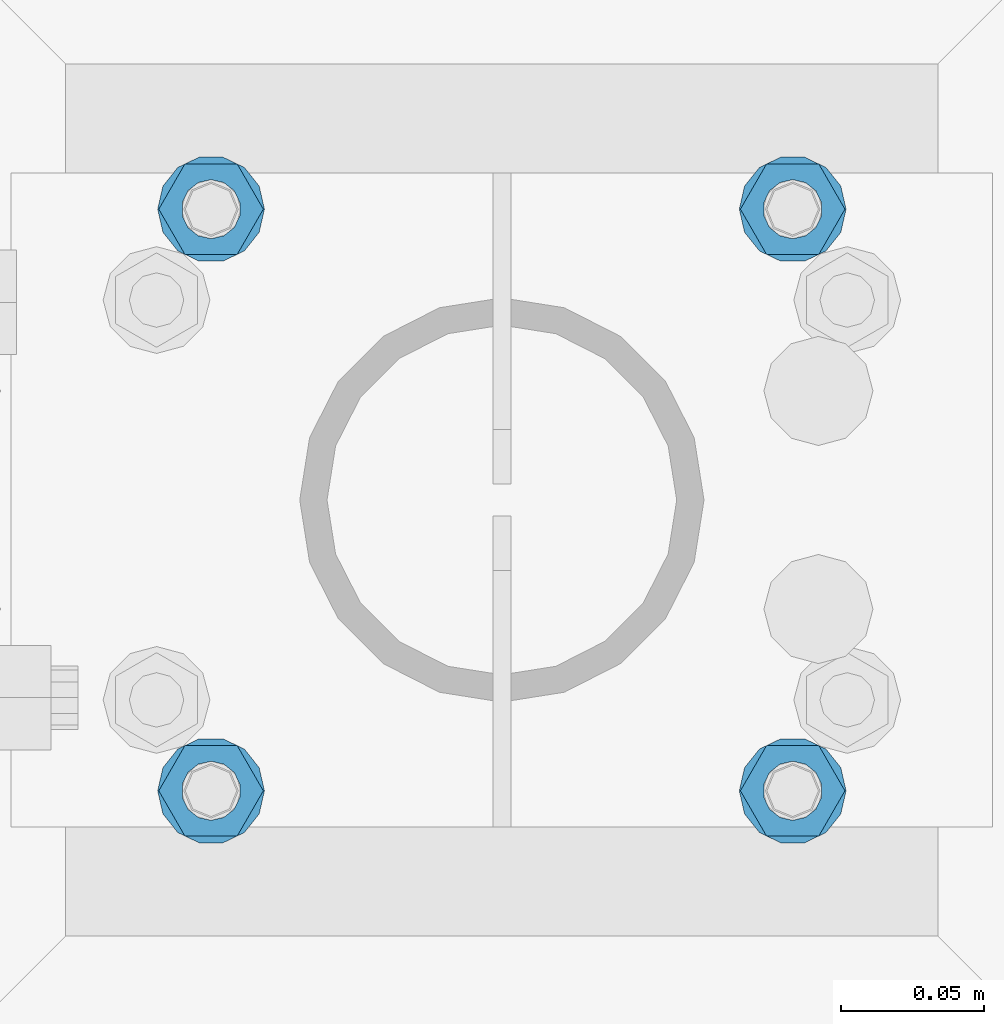
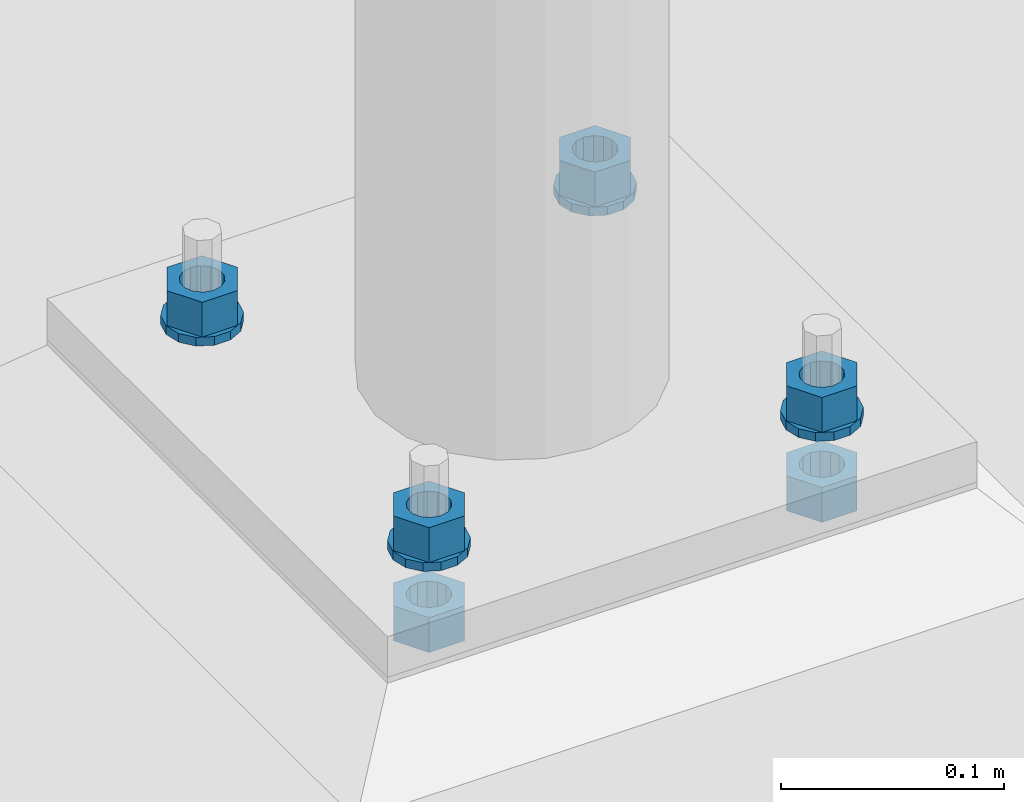
# One storey, part 545 of 975: 10 beams.
"""IFC2X3 building model written with IfcOpenShell, lengths in millimetres."""

from ifc_helpers import new_model, si_unit, frame, origin_with_axes, place, context, subcontext, project, spatial, faceted_brep, material, type_object, element, save


model = new_model("IFC2X3")

# Units and contexts
model_context = context("Model", 3, precision=1e-05, world=origin_with_axes())
body_context = subcontext(model_context, "Body", "Model", "MODEL_VIEW")
ifc_project = project(units=[si_unit("LENGTHUNIT", "METRE", prefix="MILLI"), si_unit("AREAUNIT", "SQUARE_METRE"), si_unit("VOLUMEUNIT", "CUBIC_METRE"), si_unit("MASSUNIT", "GRAM", prefix="KILO"), si_unit("TIMEUNIT", "SECOND"), si_unit("PLANEANGLEUNIT", "RADIAN"), si_unit("SOLIDANGLEUNIT", "STERADIAN"), si_unit("THERMODYNAMICTEMPERATUREUNIT", "DEGREE_CELSIUS"), si_unit("LUMINOUSINTENSITYUNIT", "LUMEN")], contexts=[model_context])

# Site, building, storey
site_placement = place(None, origin_with_axes())
site = spatial("IfcSite", under=ifc_project, at=site_placement, CompositionType="ELEMENT")
building_placement = place(site_placement, origin_with_axes())
building = spatial("IfcBuilding", under=site, at=building_placement, Name="Undefined", CompositionType="ELEMENT")
storey_placement = place(building_placement, origin_with_axes())
storey = spatial("IfcBuildingStorey", under=building, at=storey_placement, Name="Undefined", CompositionType="ELEMENT", Elevation=0.0)

# Beams
ifc_material = material(Name="STEEL/A36")
beam_type_1 = type_object("IfcBeamType", Name="3/4_WASHER", PredefinedType="NOTDEFINED")
beam_1_placement = place(storey_placement, frame((4375.15000152588, 5718.17500305176, -236.537499999998), z_axis=(0.0, -1.0, 0.0), x_axis=(0.0, 0.0, -1.0)))
element("IfcBeam", 1, at=beam_1_placement, inside=storey, type_object=beam_type_1, material=ifc_material, Name="WASHER", ObjectType="3/4_WASHER", context=body_context, shape_type="Brep", body=[
    faceted_brep([(0.0, -18.6499996185303, 0.0), (0.0, -16.8030690426876, -8.09193156902904), (4.76250000000073, -16.8030690426876, -8.09193156902904), (4.76250000000073, -18.6499996185303, 0.0), (0.0, -11.6280845668225, -14.5811568497838), (4.76250000000073, -11.6280845668225, -14.5811568497838), (0.0, -4.15001533340001, -18.1824051902857), (4.76250000000073, -4.15001533340001, -18.1824051902857), (0.0, 4.15001533340001, -18.1824051902857), (4.76250000000073, 4.15001533340001, -18.1824051902857), (0.0, 11.6280845668234, -14.5811568497838), (4.76250000000073, 11.6280845668234, -14.5811568497838), (0.0, 16.8030690426876, -8.09193156902904), (4.76250000000073, 16.8030690426876, -8.09193156902904), (0.0, 18.6499996185303, 0.0), (4.76250000000073, 18.6499996185303, 0.0), (0.0, 16.8030690426876, 8.09193156902904), (4.76250000000073, 16.8030690426876, 8.09193156902904), (0.0, 11.6280845668225, 14.5811568497838), (4.76250000000073, 11.6280845668225, 14.5811568497838), (0.0, 4.15001533340001, 18.1824051902857), (4.76250000000073, 4.15001533340001, 18.1824051902857), (0.0, -4.15001533340001, 18.1824051902857), (4.76250000000073, -4.15001533340001, 18.1824051902857), (0.0, -11.6280845668234, 14.5811568497838), (4.76250000000073, -11.6280845668234, 14.5811568497838), (0.0, -16.8030690426876, 8.09193156902904), (4.76250000000073, -16.8030690426876, 8.09193156902904), (0.0, 0.0, 10.3199996948242), (0.0, 4.47768005528269, 9.29799844179911), (4.76250000000073, 4.47768005528269, 9.29799844179911), (4.76250000000073, 0.0, 10.3199996948242), (0.0, 8.06850066047446, 6.43441456490817), (4.76250000000073, 8.06850066047446, 6.43441456490817), (0.0, 10.0612557561917, 2.29641597052117), (4.76250000000073, 10.0612557561917, 2.29641597052117), (0.0, 10.0612557561917, -2.29641597052117), (4.76250000000073, 10.0612557561917, -2.29641597052117), (0.0, 8.06850066047446, -6.43441456490814), (4.76250000000073, 8.06850066047446, -6.43441456490814), (0.0, 4.47768005528269, -9.29799844179908), (4.76250000000073, 4.47768005528269, -9.29799844179908), (0.0, 0.0, -10.3199996948242), (4.76250000000073, 0.0, -10.3199996948242), (0.0, -4.47768005528269, -9.29799844179911), (4.76250000000073, -4.47768005528269, -9.29799844179911), (0.0, -8.06850066047446, -6.43441456490817), (4.76250000000073, -8.06850066047446, -6.43441456490817), (0.0, -10.0612557561917, -2.29641597052117), (4.76250000000073, -10.0612557561917, -2.29641597052117), (0.0, -10.0612557561917, 2.29641597052117), (4.76250000000073, -10.0612557561917, 2.29641597052117), (0.0, -8.06850066047446, 6.43441456490814), (4.76250000000073, -8.06850066047446, 6.43441456490814), (0.0, -4.47768005528269, 9.29799844179908), (4.76250000000073, -4.47768005528269, 9.29799844179908)], [[[0, 1, 2, 3]], [[1, 4, 5, 2]], [[4, 6, 7, 5]], [[6, 8, 9, 7]], [[8, 10, 11, 9]], [[10, 12, 13, 11]], [[12, 14, 15, 13]], [[14, 16, 17, 15]], [[16, 18, 19, 17]], [[18, 20, 21, 19]], [[20, 22, 23, 21]], [[22, 24, 25, 23]], [[24, 26, 27, 25]], [[26, 0, 3, 27]], [[28, 29, 30, 31]], [[29, 32, 33, 30]], [[32, 34, 35, 33]], [[34, 36, 37, 35]], [[36, 38, 39, 37]], [[38, 40, 41, 39]], [[40, 42, 43, 41]], [[42, 44, 45, 43]], [[44, 46, 47, 45]], [[46, 48, 49, 47]], [[48, 50, 51, 49]], [[50, 52, 53, 51]], [[52, 54, 55, 53]], [[54, 28, 31, 55]], [[5, 7, 9, 11, 13, 15, 17, 19, 21, 23, 25, 27, 3, 2], [33, 35, 37, 39, 41, 43, 45, 47, 49, 51, 53, 55, 31, 30]], [[26, 24, 22, 20, 18, 16, 14, 12, 10, 8, 6, 4, 1, 0], [54, 52, 50, 48, 46, 44, 42, 40, 38, 36, 34, 32, 29, 28]]]),
])
beam_2_placement = place(storey_placement, frame((4578.34999847412, 5718.17500305176, -236.537499999998), z_axis=(0.0, -1.0, 0.0), x_axis=(0.0, 0.0, -1.0)))
element("IfcBeam", 2, at=beam_2_placement, inside=storey, type_object=beam_type_1, material=ifc_material, Name="WASHER", ObjectType="3/4_WASHER", context=body_context, shape_type="Brep", body=[
    faceted_brep([(0.0, -18.6499996185303, 0.0), (0.0, -16.8030690426876, -8.09193156902904), (4.76250000000073, -16.8030690426876, -8.09193156902904), (4.76250000000073, -18.6499996185303, 0.0), (0.0, -11.6280845668225, -14.5811568497838), (4.76250000000073, -11.6280845668225, -14.5811568497838), (0.0, -4.15001533340001, -18.1824051902857), (4.76250000000073, -4.15001533340001, -18.1824051902857), (0.0, 4.15001533340001, -18.1824051902857), (4.76250000000073, 4.15001533340001, -18.1824051902857), (0.0, 11.6280845668234, -14.5811568497838), (4.76250000000073, 11.6280845668234, -14.5811568497838), (0.0, 16.8030690426876, -8.09193156902904), (4.76250000000073, 16.8030690426876, -8.09193156902904), (0.0, 18.6499996185303, 0.0), (4.76250000000073, 18.6499996185303, 0.0), (0.0, 16.8030690426876, 8.09193156902904), (4.76250000000073, 16.8030690426876, 8.09193156902904), (0.0, 11.6280845668225, 14.5811568497838), (4.76250000000073, 11.6280845668225, 14.5811568497838), (0.0, 4.15001533340001, 18.1824051902857), (4.76250000000073, 4.15001533340001, 18.1824051902857), (0.0, -4.15001533340001, 18.1824051902857), (4.76250000000073, -4.15001533340001, 18.1824051902857), (0.0, -11.6280845668234, 14.5811568497838), (4.76250000000073, -11.6280845668234, 14.5811568497838), (0.0, -16.8030690426876, 8.09193156902904), (4.76250000000073, -16.8030690426876, 8.09193156902904), (0.0, 0.0, 10.3199996948242), (0.0, 4.47768005528269, 9.29799844179911), (4.76250000000073, 4.47768005528269, 9.29799844179911), (4.76250000000073, 0.0, 10.3199996948242), (0.0, 8.06850066047446, 6.43441456490817), (4.76250000000073, 8.06850066047446, 6.43441456490817), (0.0, 10.0612557561917, 2.29641597052117), (4.76250000000073, 10.0612557561917, 2.29641597052117), (0.0, 10.0612557561917, -2.29641597052117), (4.76250000000073, 10.0612557561917, -2.29641597052117), (0.0, 8.06850066047446, -6.43441456490814), (4.76250000000073, 8.06850066047446, -6.43441456490814), (0.0, 4.47768005528269, -9.29799844179908), (4.76250000000073, 4.47768005528269, -9.29799844179908), (0.0, 0.0, -10.3199996948242), (4.76250000000073, 0.0, -10.3199996948242), (0.0, -4.47768005528269, -9.29799844179911), (4.76250000000073, -4.47768005528269, -9.29799844179911), (0.0, -8.06850066047446, -6.43441456490817), (4.76250000000073, -8.06850066047446, -6.43441456490817), (0.0, -10.0612557561917, -2.29641597052117), (4.76250000000073, -10.0612557561917, -2.29641597052117), (0.0, -10.0612557561917, 2.29641597052117), (4.76250000000073, -10.0612557561917, 2.29641597052117), (0.0, -8.06850066047446, 6.43441456490814), (4.76250000000073, -8.06850066047446, 6.43441456490814), (0.0, -4.47768005528269, 9.29799844179908), (4.76250000000073, -4.47768005528269, 9.29799844179908)], [[[0, 1, 2, 3]], [[1, 4, 5, 2]], [[4, 6, 7, 5]], [[6, 8, 9, 7]], [[8, 10, 11, 9]], [[10, 12, 13, 11]], [[12, 14, 15, 13]], [[14, 16, 17, 15]], [[16, 18, 19, 17]], [[18, 20, 21, 19]], [[20, 22, 23, 21]], [[22, 24, 25, 23]], [[24, 26, 27, 25]], [[26, 0, 3, 27]], [[28, 29, 30, 31]], [[29, 32, 33, 30]], [[32, 34, 35, 33]], [[34, 36, 37, 35]], [[36, 38, 39, 37]], [[38, 40, 41, 39]], [[40, 42, 43, 41]], [[42, 44, 45, 43]], [[44, 46, 47, 45]], [[46, 48, 49, 47]], [[48, 50, 51, 49]], [[50, 52, 53, 51]], [[52, 54, 55, 53]], [[54, 28, 31, 55]], [[5, 7, 9, 11, 13, 15, 17, 19, 21, 23, 25, 27, 3, 2], [33, 35, 37, 39, 41, 43, 45, 47, 49, 51, 53, 55, 31, 30]], [[26, 24, 22, 20, 18, 16, 14, 12, 10, 8, 6, 4, 1, 0], [54, 52, 50, 48, 46, 44, 42, 40, 38, 36, 34, 32, 29, 28]]]),
])
beam_3_placement = place(storey_placement, frame((4375.15000152588, 5921.375, -236.537499999998), z_axis=(0.0, -1.0, 0.0), x_axis=(0.0, 0.0, -1.0)))
element("IfcBeam", 3, at=beam_3_placement, inside=storey, type_object=beam_type_1, material=ifc_material, Name="WASHER", ObjectType="3/4_WASHER", context=body_context, shape_type="Brep", body=[
    faceted_brep([(0.0, -18.6499996185303, 0.0), (0.0, -16.8030690426876, -8.09193156902904), (4.76250000000073, -16.8030690426876, -8.09193156902904), (4.76250000000073, -18.6499996185303, 0.0), (0.0, -11.6280845668225, -14.5811568497838), (4.76250000000073, -11.6280845668225, -14.5811568497838), (0.0, -4.15001533340001, -18.1824051902857), (4.76250000000073, -4.15001533340001, -18.1824051902857), (0.0, 4.15001533340001, -18.1824051902857), (4.76250000000073, 4.15001533340001, -18.1824051902857), (0.0, 11.6280845668234, -14.5811568497838), (4.76250000000073, 11.6280845668234, -14.5811568497838), (0.0, 16.8030690426876, -8.09193156902904), (4.76250000000073, 16.8030690426876, -8.09193156902904), (0.0, 18.6499996185303, 0.0), (4.76250000000073, 18.6499996185303, 0.0), (0.0, 16.8030690426876, 8.09193156902904), (4.76250000000073, 16.8030690426876, 8.09193156902904), (0.0, 11.6280845668225, 14.5811568497838), (4.76250000000073, 11.6280845668225, 14.5811568497838), (0.0, 4.15001533340001, 18.1824051902857), (4.76250000000073, 4.15001533340001, 18.1824051902857), (0.0, -4.15001533340001, 18.1824051902857), (4.76250000000073, -4.15001533340001, 18.1824051902857), (0.0, -11.6280845668234, 14.5811568497838), (4.76250000000073, -11.6280845668234, 14.5811568497838), (0.0, -16.8030690426876, 8.09193156902904), (4.76250000000073, -16.8030690426876, 8.09193156902904), (0.0, 0.0, 10.3199996948242), (0.0, 4.47768005528269, 9.29799844179911), (4.76250000000073, 4.47768005528269, 9.29799844179911), (4.76250000000073, 0.0, 10.3199996948242), (0.0, 8.06850066047446, 6.43441456490817), (4.76250000000073, 8.06850066047446, 6.43441456490817), (0.0, 10.0612557561917, 2.29641597052117), (4.76250000000073, 10.0612557561917, 2.29641597052117), (0.0, 10.0612557561917, -2.29641597052117), (4.76250000000073, 10.0612557561917, -2.29641597052117), (0.0, 8.06850066047446, -6.43441456490814), (4.76250000000073, 8.06850066047446, -6.43441456490814), (0.0, 4.47768005528269, -9.29799844179908), (4.76250000000073, 4.47768005528269, -9.29799844179908), (0.0, 0.0, -10.3199996948242), (4.76250000000073, 0.0, -10.3199996948242), (0.0, -4.47768005528269, -9.29799844179911), (4.76250000000073, -4.47768005528269, -9.29799844179911), (0.0, -8.06850066047446, -6.43441456490817), (4.76250000000073, -8.06850066047446, -6.43441456490817), (0.0, -10.0612557561917, -2.29641597052117), (4.76250000000073, -10.0612557561917, -2.29641597052117), (0.0, -10.0612557561917, 2.29641597052117), (4.76250000000073, -10.0612557561917, 2.29641597052117), (0.0, -8.06850066047446, 6.43441456490814), (4.76250000000073, -8.06850066047446, 6.43441456490814), (0.0, -4.47768005528269, 9.29799844179908), (4.76250000000073, -4.47768005528269, 9.29799844179908)], [[[0, 1, 2, 3]], [[1, 4, 5, 2]], [[4, 6, 7, 5]], [[6, 8, 9, 7]], [[8, 10, 11, 9]], [[10, 12, 13, 11]], [[12, 14, 15, 13]], [[14, 16, 17, 15]], [[16, 18, 19, 17]], [[18, 20, 21, 19]], [[20, 22, 23, 21]], [[22, 24, 25, 23]], [[24, 26, 27, 25]], [[26, 0, 3, 27]], [[28, 29, 30, 31]], [[29, 32, 33, 30]], [[32, 34, 35, 33]], [[34, 36, 37, 35]], [[36, 38, 39, 37]], [[38, 40, 41, 39]], [[40, 42, 43, 41]], [[42, 44, 45, 43]], [[44, 46, 47, 45]], [[46, 48, 49, 47]], [[48, 50, 51, 49]], [[50, 52, 53, 51]], [[52, 54, 55, 53]], [[54, 28, 31, 55]], [[5, 7, 9, 11, 13, 15, 17, 19, 21, 23, 25, 27, 3, 2], [33, 35, 37, 39, 41, 43, 45, 47, 49, 51, 53, 55, 31, 30]], [[26, 24, 22, 20, 18, 16, 14, 12, 10, 8, 6, 4, 1, 0], [54, 52, 50, 48, 46, 44, 42, 40, 38, 36, 34, 32, 29, 28]]]),
])
beam_4_placement = place(storey_placement, frame((4578.34999847412, 5921.375, -236.537499999998), z_axis=(0.0, -1.0, 0.0), x_axis=(0.0, 0.0, -1.0)))
element("IfcBeam", 4, at=beam_4_placement, inside=storey, type_object=beam_type_1, material=ifc_material, Name="WASHER", ObjectType="3/4_WASHER", context=body_context, shape_type="Brep", body=[
    faceted_brep([(0.0, -18.6499996185303, 0.0), (0.0, -16.8030690426876, -8.09193156902904), (4.76250000000073, -16.8030690426876, -8.09193156902904), (4.76250000000073, -18.6499996185303, 0.0), (0.0, -11.6280845668225, -14.5811568497838), (4.76250000000073, -11.6280845668225, -14.5811568497838), (0.0, -4.15001533340001, -18.1824051902857), (4.76250000000073, -4.15001533340001, -18.1824051902857), (0.0, 4.15001533340001, -18.1824051902857), (4.76250000000073, 4.15001533340001, -18.1824051902857), (0.0, 11.6280845668234, -14.5811568497838), (4.76250000000073, 11.6280845668234, -14.5811568497838), (0.0, 16.8030690426876, -8.09193156902904), (4.76250000000073, 16.8030690426876, -8.09193156902904), (0.0, 18.6499996185303, 0.0), (4.76250000000073, 18.6499996185303, 0.0), (0.0, 16.8030690426876, 8.09193156902904), (4.76250000000073, 16.8030690426876, 8.09193156902904), (0.0, 11.6280845668225, 14.5811568497838), (4.76250000000073, 11.6280845668225, 14.5811568497838), (0.0, 4.15001533340001, 18.1824051902857), (4.76250000000073, 4.15001533340001, 18.1824051902857), (0.0, -4.15001533340001, 18.1824051902857), (4.76250000000073, -4.15001533340001, 18.1824051902857), (0.0, -11.6280845668234, 14.5811568497838), (4.76250000000073, -11.6280845668234, 14.5811568497838), (0.0, -16.8030690426876, 8.09193156902904), (4.76250000000073, -16.8030690426876, 8.09193156902904), (0.0, 0.0, 10.3199996948242), (0.0, 4.47768005528269, 9.29799844179911), (4.76250000000073, 4.47768005528269, 9.29799844179911), (4.76250000000073, 0.0, 10.3199996948242), (0.0, 8.06850066047446, 6.43441456490817), (4.76250000000073, 8.06850066047446, 6.43441456490817), (0.0, 10.0612557561917, 2.29641597052117), (4.76250000000073, 10.0612557561917, 2.29641597052117), (0.0, 10.0612557561917, -2.29641597052117), (4.76250000000073, 10.0612557561917, -2.29641597052117), (0.0, 8.06850066047446, -6.43441456490814), (4.76250000000073, 8.06850066047446, -6.43441456490814), (0.0, 4.47768005528269, -9.29799844179908), (4.76250000000073, 4.47768005528269, -9.29799844179908), (0.0, 0.0, -10.3199996948242), (4.76250000000073, 0.0, -10.3199996948242), (0.0, -4.47768005528269, -9.29799844179911), (4.76250000000073, -4.47768005528269, -9.29799844179911), (0.0, -8.06850066047446, -6.43441456490817), (4.76250000000073, -8.06850066047446, -6.43441456490817), (0.0, -10.0612557561917, -2.29641597052117), (4.76250000000073, -10.0612557561917, -2.29641597052117), (0.0, -10.0612557561917, 2.29641597052117), (4.76250000000073, -10.0612557561917, 2.29641597052117), (0.0, -8.06850066047446, 6.43441456490814), (4.76250000000073, -8.06850066047446, 6.43441456490814), (0.0, -4.47768005528269, 9.29799844179908), (4.76250000000073, -4.47768005528269, 9.29799844179908)], [[[0, 1, 2, 3]], [[1, 4, 5, 2]], [[4, 6, 7, 5]], [[6, 8, 9, 7]], [[8, 10, 11, 9]], [[10, 12, 13, 11]], [[12, 14, 15, 13]], [[14, 16, 17, 15]], [[16, 18, 19, 17]], [[18, 20, 21, 19]], [[20, 22, 23, 21]], [[22, 24, 25, 23]], [[24, 26, 27, 25]], [[26, 0, 3, 27]], [[28, 29, 30, 31]], [[29, 32, 33, 30]], [[32, 34, 35, 33]], [[34, 36, 37, 35]], [[36, 38, 39, 37]], [[38, 40, 41, 39]], [[40, 42, 43, 41]], [[42, 44, 45, 43]], [[44, 46, 47, 45]], [[46, 48, 49, 47]], [[48, 50, 51, 49]], [[50, 52, 53, 51]], [[52, 54, 55, 53]], [[54, 28, 31, 55]], [[5, 7, 9, 11, 13, 15, 17, 19, 21, 23, 25, 27, 3, 2], [33, 35, 37, 39, 41, 43, 45, 47, 49, 51, 53, 55, 31, 30]], [[26, 24, 22, 20, 18, 16, 14, 12, 10, 8, 6, 4, 1, 0], [54, 52, 50, 48, 46, 44, 42, 40, 38, 36, 34, 32, 29, 28]]]),
])
beam_type_2 = type_object("IfcBeamType", Name="3/4_HEAVY_HEX_NUT", PredefinedType="NOTDEFINED")
beam_5_placement = place(storey_placement, frame((4375.15000152588, 5718.17500305176, -217.487499999999), z_axis=(0.0, -1.0, 0.0), x_axis=(0.0, 0.0, -1.0)))
element("IfcBeam", 5, at=beam_5_placement, inside=storey, type_object=beam_type_2, material=ifc_material, Name="NUT", ObjectType="3/4_HEAVY_HEX_NUT", context=body_context, shape_type="Brep", body=[
    faceted_brep([(0.0, -18.2600002288818, 0.0), (0.0, -9.13000011444092, -15.8100004196167), (19.0499999999993, -9.13000011444092, -15.8100004196167), (19.0499999999993, -18.2600002288818, 0.0), (0.0, 9.13000011444092, -15.8100004196167), (19.0499999999993, 9.13000011444092, -15.8100004196167), (0.0, 18.2600002288818, 0.0), (19.0499999999993, 18.2600002288818, 0.0), (0.0, 9.13000011444092, 15.8100004196167), (19.0499999999993, 9.13000011444092, 15.8100004196167), (0.0, -9.13000011444092, 15.8100004196167), (19.0499999999993, -9.13000011444092, 15.8100004196167), (0.0, 0.0, 10.3199996948242), (0.0, 4.47768005528269, 9.29799844179911), (19.0499999999993, 4.47768005528269, 9.29799844179911), (19.0499999999993, 0.0, 10.3199996948242), (0.0, 8.06850066047446, 6.43441456490817), (19.0499999999993, 8.06850066047446, 6.43441456490817), (0.0, 10.0612557561917, 2.29641597052117), (19.0499999999993, 10.0612557561917, 2.29641597052117), (0.0, 10.0612557561917, -2.29641597052117), (19.0499999999993, 10.0612557561917, -2.29641597052117), (0.0, 8.06850066047446, -6.43441456490814), (19.0499999999993, 8.06850066047446, -6.43441456490814), (0.0, 4.47768005528269, -9.29799844179908), (19.0499999999993, 4.47768005528269, -9.29799844179908), (0.0, 0.0, -10.3199996948242), (19.0499999999993, 0.0, -10.3199996948242), (0.0, -4.47768005528269, -9.29799844179911), (19.0499999999993, -4.47768005528269, -9.29799844179911), (0.0, -8.06850066047446, -6.43441456490817), (19.0499999999993, -8.06850066047446, -6.43441456490817), (0.0, -10.0612557561917, -2.29641597052117), (19.0499999999993, -10.0612557561917, -2.29641597052117), (0.0, -10.0612557561917, 2.29641597052117), (19.0499999999993, -10.0612557561917, 2.29641597052117), (0.0, -8.06850066047446, 6.43441456490814), (19.0499999999993, -8.06850066047446, 6.43441456490814), (0.0, -4.47768005528269, 9.29799844179908), (19.0499999999993, -4.47768005528269, 9.29799844179908)], [[[0, 1, 2, 3]], [[1, 4, 5, 2]], [[4, 6, 7, 5]], [[6, 8, 9, 7]], [[8, 10, 11, 9]], [[10, 0, 3, 11]], [[12, 13, 14, 15]], [[13, 16, 17, 14]], [[16, 18, 19, 17]], [[18, 20, 21, 19]], [[20, 22, 23, 21]], [[22, 24, 25, 23]], [[24, 26, 27, 25]], [[26, 28, 29, 27]], [[28, 30, 31, 29]], [[30, 32, 33, 31]], [[32, 34, 35, 33]], [[34, 36, 37, 35]], [[36, 38, 39, 37]], [[38, 12, 15, 39]], [[5, 7, 9, 11, 3, 2], [17, 19, 21, 23, 25, 27, 29, 31, 33, 35, 37, 39, 15, 14]], [[10, 8, 6, 4, 1, 0], [38, 36, 34, 32, 30, 28, 26, 24, 22, 20, 18, 16, 13, 12]]]),
])
beam_6_placement = place(storey_placement, frame((4578.34999847412, 5718.17500305176, -217.487499999999), z_axis=(0.0, -1.0, 0.0), x_axis=(0.0, 0.0, -1.0)))
element("IfcBeam", 6, at=beam_6_placement, inside=storey, type_object=beam_type_2, material=ifc_material, Name="NUT", ObjectType="3/4_HEAVY_HEX_NUT", context=body_context, shape_type="Brep", body=[
    faceted_brep([(0.0, -18.2600002288818, 0.0), (0.0, -9.13000011444092, -15.8100004196167), (19.0499999999993, -9.13000011444092, -15.8100004196167), (19.0499999999993, -18.2600002288818, 0.0), (0.0, 9.13000011444092, -15.8100004196167), (19.0499999999993, 9.13000011444092, -15.8100004196167), (0.0, 18.2600002288818, 0.0), (19.0499999999993, 18.2600002288818, 0.0), (0.0, 9.13000011444092, 15.8100004196167), (19.0499999999993, 9.13000011444092, 15.8100004196167), (0.0, -9.13000011444092, 15.8100004196167), (19.0499999999993, -9.13000011444092, 15.8100004196167), (0.0, 0.0, 10.3199996948242), (0.0, 4.47768005528269, 9.29799844179911), (19.0499999999993, 4.47768005528269, 9.29799844179911), (19.0499999999993, 0.0, 10.3199996948242), (0.0, 8.06850066047446, 6.43441456490817), (19.0499999999993, 8.06850066047446, 6.43441456490817), (0.0, 10.0612557561917, 2.29641597052117), (19.0499999999993, 10.0612557561917, 2.29641597052117), (0.0, 10.0612557561917, -2.29641597052117), (19.0499999999993, 10.0612557561917, -2.29641597052117), (0.0, 8.06850066047446, -6.43441456490814), (19.0499999999993, 8.06850066047446, -6.43441456490814), (0.0, 4.47768005528269, -9.29799844179908), (19.0499999999993, 4.47768005528269, -9.29799844179908), (0.0, 0.0, -10.3199996948242), (19.0499999999993, 0.0, -10.3199996948242), (0.0, -4.47768005528269, -9.29799844179911), (19.0499999999993, -4.47768005528269, -9.29799844179911), (0.0, -8.06850066047446, -6.43441456490817), (19.0499999999993, -8.06850066047446, -6.43441456490817), (0.0, -10.0612557561917, -2.29641597052117), (19.0499999999993, -10.0612557561917, -2.29641597052117), (0.0, -10.0612557561917, 2.29641597052117), (19.0499999999993, -10.0612557561917, 2.29641597052117), (0.0, -8.06850066047446, 6.43441456490814), (19.0499999999993, -8.06850066047446, 6.43441456490814), (0.0, -4.47768005528269, 9.29799844179908), (19.0499999999993, -4.47768005528269, 9.29799844179908)], [[[0, 1, 2, 3]], [[1, 4, 5, 2]], [[4, 6, 7, 5]], [[6, 8, 9, 7]], [[8, 10, 11, 9]], [[10, 0, 3, 11]], [[12, 13, 14, 15]], [[13, 16, 17, 14]], [[16, 18, 19, 17]], [[18, 20, 21, 19]], [[20, 22, 23, 21]], [[22, 24, 25, 23]], [[24, 26, 27, 25]], [[26, 28, 29, 27]], [[28, 30, 31, 29]], [[30, 32, 33, 31]], [[32, 34, 35, 33]], [[34, 36, 37, 35]], [[36, 38, 39, 37]], [[38, 12, 15, 39]], [[5, 7, 9, 11, 3, 2], [17, 19, 21, 23, 25, 27, 29, 31, 33, 35, 37, 39, 15, 14]], [[10, 8, 6, 4, 1, 0], [38, 36, 34, 32, 30, 28, 26, 24, 22, 20, 18, 16, 13, 12]]]),
])
beam_7_placement = place(storey_placement, frame((4375.15000152588, 5921.375, -217.487499999999), z_axis=(0.0, -1.0, 0.0), x_axis=(0.0, 0.0, -1.0)))
element("IfcBeam", 7, at=beam_7_placement, inside=storey, type_object=beam_type_2, material=ifc_material, Name="NUT", ObjectType="3/4_HEAVY_HEX_NUT", context=body_context, shape_type="Brep", body=[
    faceted_brep([(0.0, -18.2600002288818, 0.0), (0.0, -9.13000011444092, -15.8100004196167), (19.0499999999993, -9.13000011444092, -15.8100004196167), (19.0499999999993, -18.2600002288818, 0.0), (0.0, 9.13000011444092, -15.8100004196167), (19.0499999999993, 9.13000011444092, -15.8100004196167), (0.0, 18.2600002288818, 0.0), (19.0499999999993, 18.2600002288818, 0.0), (0.0, 9.13000011444092, 15.8100004196167), (19.0499999999993, 9.13000011444092, 15.8100004196167), (0.0, -9.13000011444092, 15.8100004196167), (19.0499999999993, -9.13000011444092, 15.8100004196167), (0.0, 0.0, 10.3199996948242), (0.0, 4.47768005528269, 9.29799844179911), (19.0499999999993, 4.47768005528269, 9.29799844179911), (19.0499999999993, 0.0, 10.3199996948242), (0.0, 8.06850066047446, 6.43441456490817), (19.0499999999993, 8.06850066047446, 6.43441456490817), (0.0, 10.0612557561917, 2.29641597052117), (19.0499999999993, 10.0612557561917, 2.29641597052117), (0.0, 10.0612557561917, -2.29641597052117), (19.0499999999993, 10.0612557561917, -2.29641597052117), (0.0, 8.06850066047446, -6.43441456490814), (19.0499999999993, 8.06850066047446, -6.43441456490814), (0.0, 4.47768005528269, -9.29799844179908), (19.0499999999993, 4.47768005528269, -9.29799844179908), (0.0, 0.0, -10.3199996948242), (19.0499999999993, 0.0, -10.3199996948242), (0.0, -4.47768005528269, -9.29799844179911), (19.0499999999993, -4.47768005528269, -9.29799844179911), (0.0, -8.06850066047446, -6.43441456490817), (19.0499999999993, -8.06850066047446, -6.43441456490817), (0.0, -10.0612557561917, -2.29641597052117), (19.0499999999993, -10.0612557561917, -2.29641597052117), (0.0, -10.0612557561917, 2.29641597052117), (19.0499999999993, -10.0612557561917, 2.29641597052117), (0.0, -8.06850066047446, 6.43441456490814), (19.0499999999993, -8.06850066047446, 6.43441456490814), (0.0, -4.47768005528269, 9.29799844179908), (19.0499999999993, -4.47768005528269, 9.29799844179908)], [[[0, 1, 2, 3]], [[1, 4, 5, 2]], [[4, 6, 7, 5]], [[6, 8, 9, 7]], [[8, 10, 11, 9]], [[10, 0, 3, 11]], [[12, 13, 14, 15]], [[13, 16, 17, 14]], [[16, 18, 19, 17]], [[18, 20, 21, 19]], [[20, 22, 23, 21]], [[22, 24, 25, 23]], [[24, 26, 27, 25]], [[26, 28, 29, 27]], [[28, 30, 31, 29]], [[30, 32, 33, 31]], [[32, 34, 35, 33]], [[34, 36, 37, 35]], [[36, 38, 39, 37]], [[38, 12, 15, 39]], [[5, 7, 9, 11, 3, 2], [17, 19, 21, 23, 25, 27, 29, 31, 33, 35, 37, 39, 15, 14]], [[10, 8, 6, 4, 1, 0], [38, 36, 34, 32, 30, 28, 26, 24, 22, 20, 18, 16, 13, 12]]]),
])
beam_8_placement = place(storey_placement, frame((4578.34999847412, 5921.375, -217.487499999999), z_axis=(0.0, -1.0, 0.0), x_axis=(0.0, 0.0, -1.0)))
element("IfcBeam", 8, at=beam_8_placement, inside=storey, type_object=beam_type_2, material=ifc_material, Name="NUT", ObjectType="3/4_HEAVY_HEX_NUT", context=body_context, shape_type="Brep", body=[
    faceted_brep([(0.0, -18.2600002288818, 0.0), (0.0, -9.13000011444092, -15.8100004196167), (19.0499999999993, -9.13000011444092, -15.8100004196167), (19.0499999999993, -18.2600002288818, 0.0), (0.0, 9.13000011444092, -15.8100004196167), (19.0499999999993, 9.13000011444092, -15.8100004196167), (0.0, 18.2600002288818, 0.0), (19.0499999999993, 18.2600002288818, 0.0), (0.0, 9.13000011444092, 15.8100004196167), (19.0499999999993, 9.13000011444092, 15.8100004196167), (0.0, -9.13000011444092, 15.8100004196167), (19.0499999999993, -9.13000011444092, 15.8100004196167), (0.0, 0.0, 10.3199996948242), (0.0, 4.47768005528269, 9.29799844179911), (19.0499999999993, 4.47768005528269, 9.29799844179911), (19.0499999999993, 0.0, 10.3199996948242), (0.0, 8.06850066047446, 6.43441456490817), (19.0499999999993, 8.06850066047446, 6.43441456490817), (0.0, 10.0612557561917, 2.29641597052117), (19.0499999999993, 10.0612557561917, 2.29641597052117), (0.0, 10.0612557561917, -2.29641597052117), (19.0499999999993, 10.0612557561917, -2.29641597052117), (0.0, 8.06850066047446, -6.43441456490814), (19.0499999999993, 8.06850066047446, -6.43441456490814), (0.0, 4.47768005528269, -9.29799844179908), (19.0499999999993, 4.47768005528269, -9.29799844179908), (0.0, 0.0, -10.3199996948242), (19.0499999999993, 0.0, -10.3199996948242), (0.0, -4.47768005528269, -9.29799844179911), (19.0499999999993, -4.47768005528269, -9.29799844179911), (0.0, -8.06850066047446, -6.43441456490817), (19.0499999999993, -8.06850066047446, -6.43441456490817), (0.0, -10.0612557561917, -2.29641597052117), (19.0499999999993, -10.0612557561917, -2.29641597052117), (0.0, -10.0612557561917, 2.29641597052117), (19.0499999999993, -10.0612557561917, 2.29641597052117), (0.0, -8.06850066047446, 6.43441456490814), (19.0499999999993, -8.06850066047446, 6.43441456490814), (0.0, -4.47768005528269, 9.29799844179908), (19.0499999999993, -4.47768005528269, 9.29799844179908)], [[[0, 1, 2, 3]], [[1, 4, 5, 2]], [[4, 6, 7, 5]], [[6, 8, 9, 7]], [[8, 10, 11, 9]], [[10, 0, 3, 11]], [[12, 13, 14, 15]], [[13, 16, 17, 14]], [[16, 18, 19, 17]], [[18, 20, 21, 19]], [[20, 22, 23, 21]], [[22, 24, 25, 23]], [[24, 26, 27, 25]], [[26, 28, 29, 27]], [[28, 30, 31, 29]], [[30, 32, 33, 31]], [[32, 34, 35, 33]], [[34, 36, 37, 35]], [[36, 38, 39, 37]], [[38, 12, 15, 39]], [[5, 7, 9, 11, 3, 2], [17, 19, 21, 23, 25, 27, 29, 31, 33, 35, 37, 39, 15, 14]], [[10, 8, 6, 4, 1, 0], [38, 36, 34, 32, 30, 28, 26, 24, 22, 20, 18, 16, 13, 12]]]),
])
beam_9_placement = place(storey_placement, frame((4375.15000152588, 5718.17500305176, -266.7), z_axis=(0.0, -1.0, 0.0), x_axis=(0.0, 0.0, -1.0)))
element("IfcBeam", 9, at=beam_9_placement, inside=storey, type_object=beam_type_2, material=ifc_material, Name="NUT", ObjectType="3/4_HEAVY_HEX_NUT", context=body_context, shape_type="Brep", body=[
    faceted_brep([(0.0, -18.2600002288818, 0.0), (0.0, -9.13000011444092, -15.8100004196167), (19.0499999999993, -9.13000011444092, -15.8100004196167), (19.0499999999993, -18.2600002288818, 0.0), (0.0, 9.13000011444092, -15.8100004196167), (19.0499999999993, 9.13000011444092, -15.8100004196167), (0.0, 18.2600002288818, 0.0), (19.0499999999993, 18.2600002288818, 0.0), (0.0, 9.13000011444092, 15.8100004196167), (19.0499999999993, 9.13000011444092, 15.8100004196167), (0.0, -9.13000011444092, 15.8100004196167), (19.0499999999993, -9.13000011444092, 15.8100004196167), (0.0, 0.0, 10.3199996948242), (0.0, 4.47768005528269, 9.29799844179911), (19.0499999999993, 4.47768005528269, 9.29799844179911), (19.0499999999993, 0.0, 10.3199996948242), (0.0, 8.06850066047446, 6.43441456490817), (19.0499999999993, 8.06850066047446, 6.43441456490817), (0.0, 10.0612557561917, 2.29641597052117), (19.0499999999993, 10.0612557561917, 2.29641597052117), (0.0, 10.0612557561917, -2.29641597052117), (19.0499999999993, 10.0612557561917, -2.29641597052117), (0.0, 8.06850066047446, -6.43441456490814), (19.0499999999993, 8.06850066047446, -6.43441456490814), (0.0, 4.47768005528269, -9.29799844179908), (19.0499999999993, 4.47768005528269, -9.29799844179908), (0.0, 0.0, -10.3199996948242), (19.0499999999993, 0.0, -10.3199996948242), (0.0, -4.47768005528269, -9.29799844179911), (19.0499999999993, -4.47768005528269, -9.29799844179911), (0.0, -8.06850066047446, -6.43441456490817), (19.0499999999993, -8.06850066047446, -6.43441456490817), (0.0, -10.0612557561917, -2.29641597052117), (19.0499999999993, -10.0612557561917, -2.29641597052117), (0.0, -10.0612557561917, 2.29641597052117), (19.0499999999993, -10.0612557561917, 2.29641597052117), (0.0, -8.06850066047446, 6.43441456490814), (19.0499999999993, -8.06850066047446, 6.43441456490814), (0.0, -4.47768005528269, 9.29799844179908), (19.0499999999993, -4.47768005528269, 9.29799844179908)], [[[0, 1, 2, 3]], [[1, 4, 5, 2]], [[4, 6, 7, 5]], [[6, 8, 9, 7]], [[8, 10, 11, 9]], [[10, 0, 3, 11]], [[12, 13, 14, 15]], [[13, 16, 17, 14]], [[16, 18, 19, 17]], [[18, 20, 21, 19]], [[20, 22, 23, 21]], [[22, 24, 25, 23]], [[24, 26, 27, 25]], [[26, 28, 29, 27]], [[28, 30, 31, 29]], [[30, 32, 33, 31]], [[32, 34, 35, 33]], [[34, 36, 37, 35]], [[36, 38, 39, 37]], [[38, 12, 15, 39]], [[5, 7, 9, 11, 3, 2], [17, 19, 21, 23, 25, 27, 29, 31, 33, 35, 37, 39, 15, 14]], [[10, 8, 6, 4, 1, 0], [38, 36, 34, 32, 30, 28, 26, 24, 22, 20, 18, 16, 13, 12]]]),
])
beam_10_placement = place(storey_placement, frame((4578.34999847412, 5718.17500305176, -266.7), z_axis=(0.0, -1.0, 0.0), x_axis=(0.0, 0.0, -1.0)))
element("IfcBeam", 10, at=beam_10_placement, inside=storey, type_object=beam_type_2, material=ifc_material, Name="NUT", ObjectType="3/4_HEAVY_HEX_NUT", context=body_context, shape_type="Brep", body=[
    faceted_brep([(0.0, -18.2600002288818, 0.0), (0.0, -9.13000011444092, -15.8100004196167), (19.0499999999993, -9.13000011444092, -15.8100004196167), (19.0499999999993, -18.2600002288818, 0.0), (0.0, 9.13000011444092, -15.8100004196167), (19.0499999999993, 9.13000011444092, -15.8100004196167), (0.0, 18.2600002288818, 0.0), (19.0499999999993, 18.2600002288818, 0.0), (0.0, 9.13000011444092, 15.8100004196167), (19.0499999999993, 9.13000011444092, 15.8100004196167), (0.0, -9.13000011444092, 15.8100004196167), (19.0499999999993, -9.13000011444092, 15.8100004196167), (0.0, 0.0, 10.3199996948242), (0.0, 4.47768005528269, 9.29799844179911), (19.0499999999993, 4.47768005528269, 9.29799844179911), (19.0499999999993, 0.0, 10.3199996948242), (0.0, 8.06850066047446, 6.43441456490817), (19.0499999999993, 8.06850066047446, 6.43441456490817), (0.0, 10.0612557561917, 2.29641597052117), (19.0499999999993, 10.0612557561917, 2.29641597052117), (0.0, 10.0612557561917, -2.29641597052117), (19.0499999999993, 10.0612557561917, -2.29641597052117), (0.0, 8.06850066047446, -6.43441456490814), (19.0499999999993, 8.06850066047446, -6.43441456490814), (0.0, 4.47768005528269, -9.29799844179908), (19.0499999999993, 4.47768005528269, -9.29799844179908), (0.0, 0.0, -10.3199996948242), (19.0499999999993, 0.0, -10.3199996948242), (0.0, -4.47768005528269, -9.29799844179911), (19.0499999999993, -4.47768005528269, -9.29799844179911), (0.0, -8.06850066047446, -6.43441456490817), (19.0499999999993, -8.06850066047446, -6.43441456490817), (0.0, -10.0612557561917, -2.29641597052117), (19.0499999999993, -10.0612557561917, -2.29641597052117), (0.0, -10.0612557561917, 2.29641597052117), (19.0499999999993, -10.0612557561917, 2.29641597052117), (0.0, -8.06850066047446, 6.43441456490814), (19.0499999999993, -8.06850066047446, 6.43441456490814), (0.0, -4.47768005528269, 9.29799844179908), (19.0499999999993, -4.47768005528269, 9.29799844179908)], [[[0, 1, 2, 3]], [[1, 4, 5, 2]], [[4, 6, 7, 5]], [[6, 8, 9, 7]], [[8, 10, 11, 9]], [[10, 0, 3, 11]], [[12, 13, 14, 15]], [[13, 16, 17, 14]], [[16, 18, 19, 17]], [[18, 20, 21, 19]], [[20, 22, 23, 21]], [[22, 24, 25, 23]], [[24, 26, 27, 25]], [[26, 28, 29, 27]], [[28, 30, 31, 29]], [[30, 32, 33, 31]], [[32, 34, 35, 33]], [[34, 36, 37, 35]], [[36, 38, 39, 37]], [[38, 12, 15, 39]], [[5, 7, 9, 11, 3, 2], [17, 19, 21, 23, 25, 27, 29, 31, 33, 35, 37, 39, 15, 14]], [[10, 8, 6, 4, 1, 0], [38, 36, 34, 32, 30, 28, 26, 24, 22, 20, 18, 16, 13, 12]]]),
])

save(model, "model.ifc")
